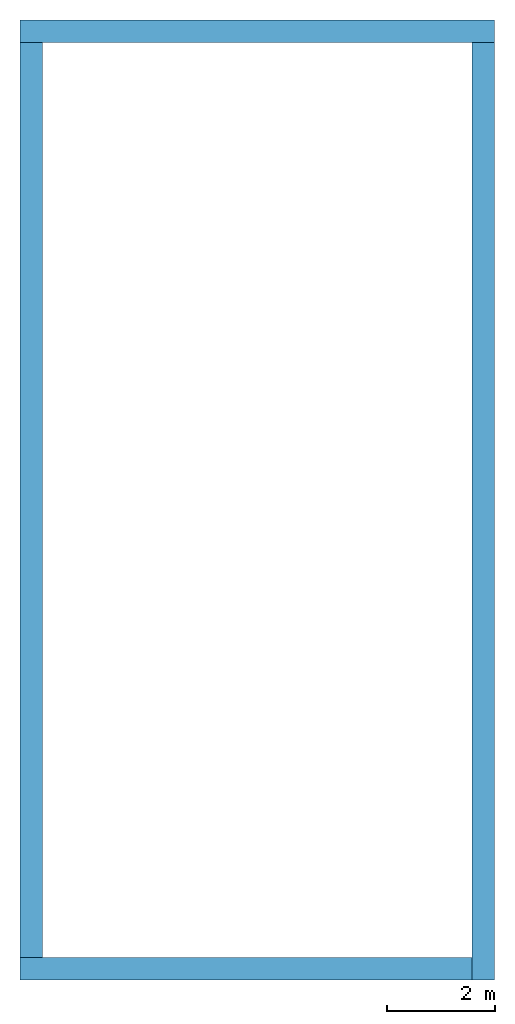
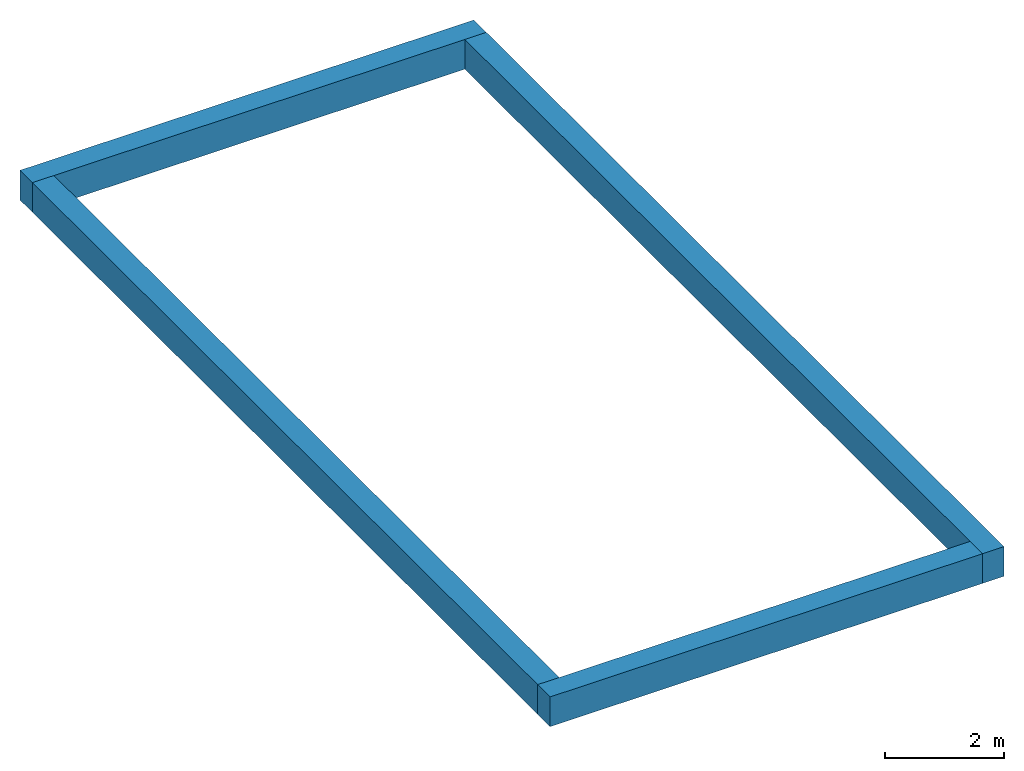
# One storey: 4 walls.
"""IFC2X3 building model written with IfcOpenShell, lengths in metres."""

from ifc_helpers import new_model, entity, si_unit, converted_unit, frame, frame_2d, origin, place, context, project, spatial, rectangle, extrude, material, layer, layer_set, layer_usage, element, save


model = new_model("IFC2X3")

# Units and contexts
model_context = context("Model", 3, precision=1e-09, world=origin())
plan_context = context("Plan", 3, precision=1e-09, world=origin())
ifc_project = project(units=[si_unit("LENGTHUNIT", "METRE"), si_unit("AREAUNIT", "SQUARE_METRE"), si_unit("VOLUMEUNIT", "CUBIC_METRE"), converted_unit("PLANEANGLEUNIT", "DEGREE", entity("IfcRatioMeasure", 0.01745329251994328), si_unit("PLANEANGLEUNIT", "RADIAN"), dimensions=[0, 0, 0, 0, 0, 0, 0]), si_unit("TIMEUNIT", "SECOND")], contexts=[model_context, plan_context])

# Site, building, storey
site_placement = place(None, origin())
site = spatial("IfcSite", under=ifc_project, at=site_placement, CompositionType="ELEMENT")
building_placement = place(site_placement, origin())
building = spatial("IfcBuilding", under=site, at=building_placement, CompositionType="ELEMENT")
storey_placement = place(building_placement, frame((0.0, 0.0, 6.0)))
storey = spatial("IfcBuildingStorey", under=building, at=storey_placement, Name="Roof", CompositionType="ELEMENT", Elevation=6.000000000000207)

# Walls
ifc_material_1 = material(Name="Masonry - Brick")
ifc_layer_1 = layer(ifc_material_1, 0.092)
ifc_material_2 = material(Name="Misc. Air Layers - Air Space")
ifc_layer_2 = layer(ifc_material_2, 0.025)
ifc_material_3 = material(Name="Insulation / Thermal Barriers - Rigid insulation")
ifc_layer_3 = layer(ifc_material_3, 0.05)
ifc_material_4 = material(Name="Masonry - Concrete Block")
ifc_layer_4 = layer(ifc_material_4, 0.193)
ifc_material_5 = material(Name="Metal - Stud Layer")
ifc_layer_5 = layer(ifc_material_5, 0.041)
ifc_material_6 = material(Name="Plasterboard")
ifc_layer_6 = layer(ifc_material_6, 0.016)
ifc_layer_set = layer_set([ifc_layer_1, ifc_layer_2, ifc_layer_3, ifc_layer_4, ifc_layer_5, ifc_layer_6], Name="Basic Wall:Exterior - Brick on Block")
ifc_layer_usage_1 = layer_usage(ifc_layer_set, "AXIS2", "NEGATIVE", 0.2085000000000001)
wall_1_placement = place(storey_placement, frame((0.0, -0.2085000000000001, 0.0)))
element("IfcWallStandardCase", 1, at=wall_1_placement, inside=storey, material=ifc_layer_usage_1, Name="Basic Wall:Exterior - Brick on Block", ObjectType="Basic Wall:Exterior - Brick on Block", context=model_context, shape_type="SweptSolid", body=[
    extrude(rectangle(XDim=8.800000000000002, YDim=0.4170000000000001, at=frame_2d((4.400000000000001, 0.0), x_axis=(-1.0, 0.0))), origin(), (0.0, 0.0, 1.0), 0.6090000000000002),
])
ifc_layer_usage_2 = layer_usage(ifc_layer_set, "AXIS2", "NEGATIVE", 0.2085000000000001)
wall_2_placement = place(storey_placement, frame((8.5915, -0.4170000000000275, 0.0), z_axis=(0.0, 0.0, 1.0), x_axis=(0.0, -1.0, 0.0)))
element("IfcWallStandardCase", 2, at=wall_2_placement, inside=storey, material=ifc_layer_usage_2, Name="Basic Wall:Exterior - Brick on Block", ObjectType="Basic Wall:Exterior - Brick on Block", context=model_context, shape_type="SweptSolid", body=[
    extrude(rectangle(XDim=17.38299999999997, YDim=0.4170000000000005, at=frame_2d((8.691499999999987, 0.0), x_axis=(-1.0, 0.0))), origin(), (0.0, 0.0, 1.0), 0.6090000000000002),
])
ifc_layer_usage_3 = layer_usage(ifc_layer_set, "AXIS2", "NEGATIVE", 0.2085000000000001)
wall_3_placement = place(storey_placement, frame((8.382999999999972, -17.5915, 0.0), z_axis=(0.0, 0.0, 1.0), x_axis=(-1.0, 0.0, 0.0)))
element("IfcWallStandardCase", 3, at=wall_3_placement, inside=storey, material=ifc_layer_usage_3, Name="Basic Wall:Exterior - Brick on Block", ObjectType="Basic Wall:Exterior - Brick on Block", context=model_context, shape_type="SweptSolid", body=[
    extrude(rectangle(XDim=8.382999999999974, YDim=0.4170000000000005, at=frame_2d((4.191499999999987, 0.0), x_axis=(-1.0, 0.0))), origin(), (0.0, 0.0, 1.0), 0.6090000000000002),
])
ifc_layer_usage_4 = layer_usage(ifc_layer_set, "AXIS2", "NEGATIVE", 0.2085000000000001)
wall_4_placement = place(storey_placement, frame((0.208499999999999, -17.38299999999997, 0.0), z_axis=(0.0, 0.0, 1.0), x_axis=(0.0, 1.0, 0.0)))
element("IfcWallStandardCase", 4, at=wall_4_placement, inside=storey, material=ifc_layer_usage_4, Name="Basic Wall:Exterior - Brick on Block", ObjectType="Basic Wall:Exterior - Brick on Block", context=model_context, shape_type="SweptSolid", body=[
    extrude(rectangle(XDim=16.96599999999997, YDim=0.4170000000000001, at=frame_2d((8.482999999999986, 0.0), x_axis=(-1.0, 0.0))), origin(), (0.0, 0.0, 1.0), 0.6090000000000002),
])

save(model, "model.ifc")
